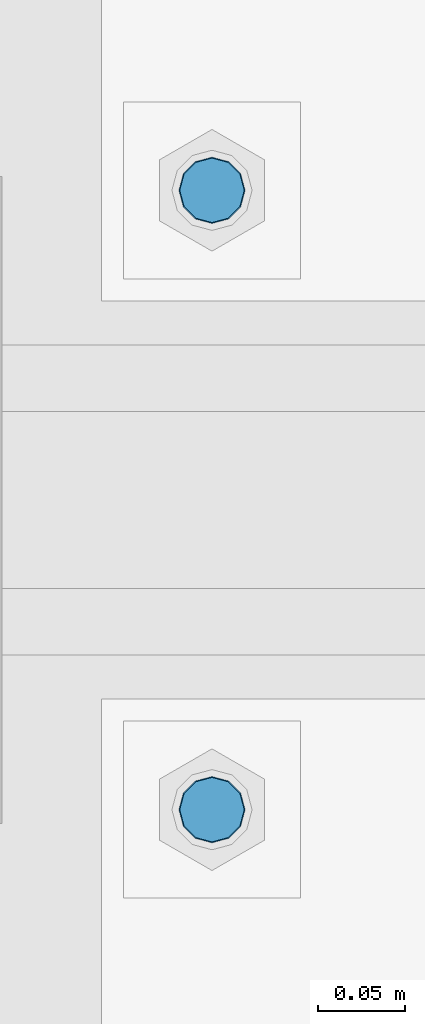
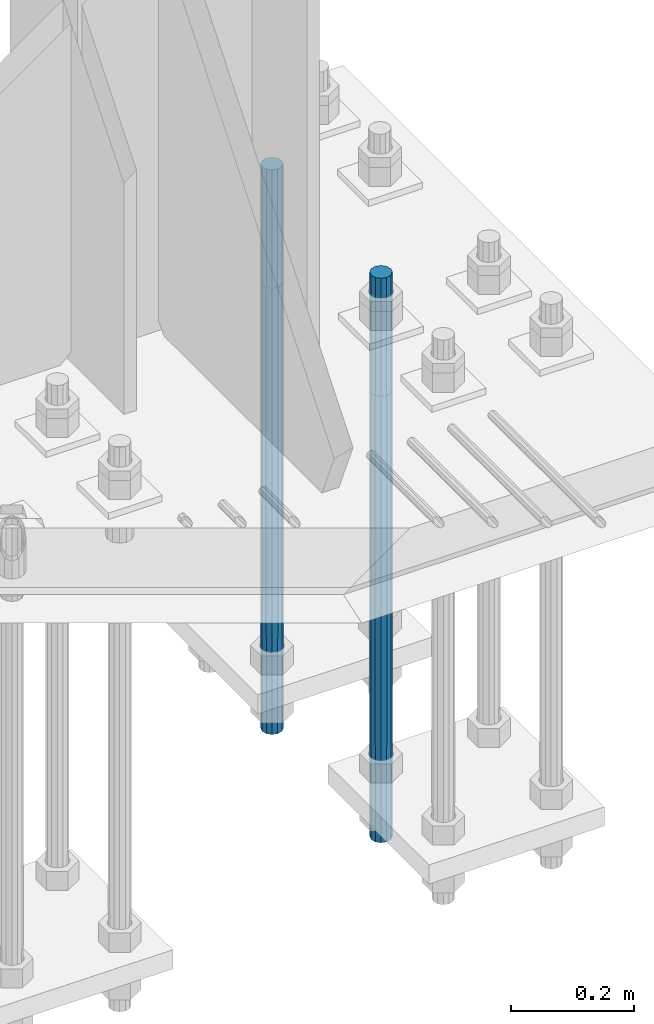
# One storey, part 1429 of 3843: 2 columns, 1 element without a shape of its own.
"""IFC2X3 building model written with IfcOpenShell, lengths in millimetres."""

import ifcopenshell
import ifcopenshell.guid

model = None  # the IFC model being written
_history = None  # IfcOwnerHistory: only IFC2X3 demands one
_inside = {}  # id of a spatial element -> (the spatial element, [elements in it])
_under = {}  # id of a project, library or spatial element -> (it, [spatial elements below it])
_declared = {}  # id of a project -> (the project, [libraries it declares])
_typed = {}  # id of a type object -> (the type object, [elements of that type])
_made_of = {}  # id of a material, layer set ... -> (it, [elements and type objects made of it])


def new_model(schema):
    """Start an empty IFC model of exactly this schema.

    Asked for "IFC4X3", IfcOpenShell would pick the latest addendum, in which some entities
    have other attributes; the version numbers below select the first issue.
    IFC2X3 requires an IfcOwnerHistory on every rooted entity: one is made here for all.
    """
    global model, _history
    if schema == "IFC4X3":
        model = ifcopenshell.file(schema_version=(4, 3, 0, 0))
    else:
        model = ifcopenshell.file(schema=schema)
    _inside.clear()
    _under.clear()
    _declared.clear()
    _typed.clear()
    _made_of.clear()
    _history = None
    if model.schema == "IFC2X3":
        org = make("IfcOrganization", Name="unknown")
        user = make(
            "IfcPersonAndOrganization",
            ThePerson=make("IfcPerson", FamilyName="unknown"),
            TheOrganization=org,
        )
        app = make(
            "IfcApplication",
            ApplicationDeveloper=org,
            Version="unknown",
            ApplicationFullName="unknown",
            ApplicationIdentifier="unknown",
        )
        _history = make(
            "IfcOwnerHistory",
            OwningUser=user,
            OwningApplication=app,
            ChangeAction="ADDED",
            CreationDate=0,
        )
    return model


def make(cls, **values):
    """One entity of the class cls with the attributes given. An attribute that is None is left unset."""
    return model.create_entity(
        cls, **{name: value for name, value in values.items() if value is not None}
    )


def rooted(cls, **values):
    """An entity with a GlobalId (a new one), such as an element, a storey or a relation."""
    return make(cls, GlobalId=ifcopenshell.guid.new(), OwnerHistory=_history, **values)


def si_unit(unit_type, name, prefix=None):
    """IfcSIUnit, for example si_unit("LENGTHUNIT", "METRE", prefix="MILLI")."""
    return make("IfcSIUnit", UnitType=unit_type, Prefix=prefix, Name=name)


def assignment(units):
    """IfcUnitAssignment: the units of a project."""
    return None if units is None else make("IfcUnitAssignment", Units=units)


def point(xyz):
    """IfcCartesianPoint."""
    return None if xyz is None else make("IfcCartesianPoint", Coordinates=xyz)


def direction(xyz):
    """IfcDirection."""
    return None if xyz is None else make("IfcDirection", DirectionRatios=xyz)


def frame(location, z_axis=None, x_axis=None):
    """IfcAxis2Placement3D, a coordinate frame: its origin and axes. An axis left out is left unset."""
    return make(
        "IfcAxis2Placement3D",
        Location=point(location),
        Axis=direction(z_axis),
        RefDirection=direction(x_axis),
    )


def origin_with_axes():
    """The frame at (0, 0, 0) with the z axis (0, 0, 1) and the x axis (1, 0, 0) written out."""
    return frame((0.0, 0.0, 0.0), z_axis=(0.0, 0.0, 1.0), x_axis=(1.0, 0.0, 0.0))


def place(relative_to, where):
    """IfcLocalPlacement: puts the frame where relative to a parent placement (None: the world)."""
    return make(
        "IfcLocalPlacement", PlacementRelTo=relative_to, RelativePlacement=where
    )


def context(
    kind, dimensions, precision=None, world=None, true_north=None, identifier=None
):
    """IfcGeometricRepresentationContext, for example the 3D "Model" context."""
    return make(
        "IfcGeometricRepresentationContext",
        ContextIdentifier=identifier,
        ContextType=kind,
        CoordinateSpaceDimension=dimensions,
        Precision=precision,
        WorldCoordinateSystem=world,
        TrueNorth=true_north,
    )


def subcontext(parent, identifier, kind, view, scale=None):
    """IfcGeometricRepresentationSubContext, for example "Body" below "Model"."""
    return make(
        "IfcGeometricRepresentationSubContext",
        ContextIdentifier=identifier,
        ContextType=kind,
        ParentContext=parent,
        TargetScale=scale,
        TargetView=view,
    )


def project(units=None, contexts=None):
    """IfcProject with its units and contexts."""
    return rooted(
        "IfcProject",
        Name="project",
        RepresentationContexts=contexts,
        UnitsInContext=assignment(units),
    )


def spatial(cls, under=None, at=None, **own):
    """A site, building, storey or space (cls), placed at a placement, below another one or the project."""
    s = rooted(cls, ObjectPlacement=at, **own)
    if under is not None:
        _under.setdefault(under.id(), (under, []))[1].append(s)
    return s


def faces_of(points, faces, orient=None, outer=None):
    """IfcFace entities. A face is a list of loops; a loop is a list of indices into points, from 0.

    orient and outer hold one flag for each loop. By default every Orientation is true, the
    first loop of a face is its IfcFaceOuterBound and the others are IfcFaceBound.
    """
    made = []
    for i, loops in enumerate(faces):
        bounds = []
        for j, loop in enumerate(loops):
            is_outer = j == 0 if outer is None else outer[i][j]
            bounds.append(
                make(
                    "IfcFaceOuterBound" if is_outer else "IfcFaceBound",
                    Bound=make("IfcPolyLoop", Polygon=[points[k] for k in loop]),
                    Orientation=True if orient is None else orient[i][j],
                )
            )
        made.append(make("IfcFace", Bounds=bounds))
    return made


def faceted_brep(points, faces, orient=None, outer=None, voids=None):
    """IfcFacetedBrep: a solid bounded by flat faces; with voids (closed shells), ...WithVoids."""
    shared = [point(p) for p in points]
    hull = make("IfcClosedShell", CfsFaces=faces_of(shared, faces, orient, outer))
    if voids is None:
        return make("IfcFacetedBrep", Outer=hull)
    return make(
        "IfcFacetedBrepWithVoids",
        Outer=hull,
        Voids=[
            make(cls, CfsFaces=faces_of(shared, fs, o, b)) for cls, fs, o, b in voids
        ],
    )


def shape(context_of_items, identifier, shape_type, items):
    """IfcShapeRepresentation: the items that make up one representation, for example the "Body"."""
    return make(
        "IfcShapeRepresentation",
        ContextOfItems=context_of_items,
        RepresentationIdentifier=identifier,
        RepresentationType=shape_type,
        Items=items,
    )


def material(Name=None, Category=None):
    """IfcMaterial."""
    return make("IfcMaterial", Name=Name, Category=Category)


def made_of(thing, what):
    """Note that an element or type object is made of a material, layer set ...; save() writes the relation."""
    if what is not None:
        _made_of.setdefault(what.id(), (what, []))[1].append(thing)
    return thing


def type_object(cls, material=None, **own):
    """A type object (cls), such as IfcWallType, which elements share."""
    return made_of(rooted(cls, **own), material)


def element(
    cls,
    number,
    at=None,
    inside=None,
    cuts=None,
    type_object=None,
    material=None,
    context=None,
    identifier="Body",
    shape_type=None,
    held_by="IfcProductDefinitionShape",
    body=None,
    shapes=None,
    **own,
):
    """One element of the class cls, such as IfcWall. Its Tag is "e" and its number.

    at: its placement. inside: the storey or other place that contains it. cuts: it is an
    opening in that element (IfcRelVoidsElement). A single representation is given by context,
    identifier, shape_type and body (its items); several are given by shapes. held_by: the class
    of the entity that holds the representations. save() writes the other relations.
    """
    e = rooted(cls, Tag="e%d" % number, ObjectPlacement=at, **own)
    if body is not None:
        shapes = [shape(context, identifier, shape_type, body)]
    if shapes is not None:
        e.Representation = make(held_by, Representations=shapes)
    if inside is not None:
        _inside.setdefault(inside.id(), (inside, []))[1].append(e)
    if cuts is not None:
        rooted(
            "IfcRelVoidsElement", RelatingBuildingElement=cuts, RelatedOpeningElement=e
        )
    if type_object is not None:
        _typed.setdefault(type_object.id(), (type_object, []))[1].append(e)
    return made_of(e, material)


def aggregate(whole, parts):
    """IfcRelAggregates: a whole, such as a stair, and the parts it consists of."""
    return rooted("IfcRelAggregates", RelatingObject=whole, RelatedObjects=parts)


def save(model, path):
    """Write the relations noted so far, then the file.

    IfcRelAggregates (storeys below a building ...), IfcRelContainedInSpatialStructure (elements
    in a storey), IfcRelDefinesByType, IfcRelAssociatesMaterial and IfcRelDeclares: one each for
    every whole, place, type object, material and project.
    """
    for whole, parts in _under.values():
        aggregate(whole, parts)
    for where, things in _inside.values():
        rooted(
            "IfcRelContainedInSpatialStructure",
            RelatedElements=things,
            RelatingStructure=where,
        )
    for kind, things in _typed.values():
        rooted("IfcRelDefinesByType", RelatedObjects=things, RelatingType=kind)
    for what, things in _made_of.values():
        rooted("IfcRelAssociatesMaterial", RelatedObjects=things, RelatingMaterial=what)
    for by, libraries in _declared.values():
        rooted("IfcRelDeclares", RelatingContext=by, RelatedDefinitions=libraries)
    model.write(path)


model = new_model("IFC2X3")

# Units and contexts
model_context = context("Model", 3, precision=1e-05, world=origin_with_axes())
body_context = subcontext(model_context, "Body", "Model", "MODEL_VIEW")
ifc_project = project(units=[si_unit("LENGTHUNIT", "METRE", prefix="MILLI"), si_unit("AREAUNIT", "SQUARE_METRE"), si_unit("VOLUMEUNIT", "CUBIC_METRE"), si_unit("MASSUNIT", "GRAM", prefix="KILO"), si_unit("TIMEUNIT", "SECOND"), si_unit("PLANEANGLEUNIT", "RADIAN"), si_unit("SOLIDANGLEUNIT", "STERADIAN"), si_unit("THERMODYNAMICTEMPERATUREUNIT", "DEGREE_CELSIUS"), si_unit("LUMINOUSINTENSITYUNIT", "LUMEN")], contexts=[model_context])

# Site, building, storey
site_placement = place(None, origin_with_axes())
site = spatial("IfcSite", under=ifc_project, at=site_placement, CompositionType="ELEMENT")
building_placement = place(site_placement, origin_with_axes())
building = spatial("IfcBuilding", under=site, at=building_placement, Name="Undefined", CompositionType="ELEMENT")
storey_placement = place(building_placement, origin_with_axes())
storey = spatial("IfcBuildingStorey", under=building, at=storey_placement, Name="Undefined", CompositionType="ELEMENT", Elevation=0.0)

# Assembly, columns
assembly_placement = place(storey_placement, origin_with_axes())
assembly = element("IfcElementAssembly", 1, at=assembly_placement, inside=storey, Name="TEMPLATE", AssemblyPlace="NOTDEFINED", PredefinedType="RIGID_FRAME")
ifc_material = material(Name="Undefined/F1554-GR.55")
column_type = type_object("IfcColumnType", PredefinedType="NOTDEFINED")
column_1_placement = place(assembly_placement, frame((85953.6, 104381.3, 29565.6), z_axis=(1.0, 0.0, 0.0), x_axis=(0.0, 0.0, -1.0)))
column_1 = element("IfcColumn", 2, at=column_1_placement, type_object=column_type, material=ifc_material, Name="ANCHOR_ROD", context=body_context, shape_type="Brep", body=[
    faceted_brep([(-234.950000000001, -16.0214699700155, 9.25), (-234.950000000001, -9.25, 16.0214699700155), (-234.950000000001, 0.0, 18.5), (-234.950000000001, 9.25, 16.0214699700155), (-234.950000000001, 16.0214699700155, 9.25), (-234.950000000001, 18.5, 0.0), (-234.950000000001, 16.0214699700155, -9.25), (-234.950000000001, 9.25, -16.0214699700155), (-234.950000000001, 0.0, -18.5), (-234.950000000001, -9.25, -16.0214699700155), (-234.950000000001, -16.0214699700155, -9.25), (-234.950000000001, -18.5, 0.0), (0.0, 18.5, 0.0), (0.0, 16.0214699700118, -9.25), (0.0, 9.25, -16.0214699700155), (0.0, 0.0, -18.5), (0.0, -9.25, -16.0214699700155), (0.0, -16.0214699700118, -9.25), (0.0, -18.5, 0.0), (0.0, -16.0214699700118, 9.25), (0.0, -9.25, 16.0214699700155), (0.0, 0.0, 18.5), (0.0, 9.25, 16.0214699700155), (0.0, 16.0214699700118, 9.25), (0.0, -16.4977839420972, 9.52500000000146), (0.0, -9.52500000000146, 16.4977839420972), (0.0, 0.0, 19.0499989999989), (0.0, 9.52500000000146, 16.4977839420972), (0.0, 16.4977839420972, 9.52500000000146), (0.0, 19.0500000000029, 0.0), (0.0, 16.4977839420972, -9.52500000000146), (0.0, 9.52500000000146, -16.4977839420972), (0.0, 0.0, -19.0499989999989), (0.0, -9.52500000000146, -16.4977839420972), (0.0, -16.4977839420972, -9.52500000000146), (0.0, -19.0500000000029, 0.0), (698.5, -19.0499999999993, 0.0), (698.5, -16.4977839420935, 9.52499999999418), (698.5, -9.52500000000146, 16.4977839420899), (698.5, 0.0, 19.0500000000029), (698.5, 9.52500000000146, 16.4977839420899), (698.5, 16.4977839420935, 9.52499999999418), (698.5, 19.0499999999993, 0.0), (698.5, 16.4977839420935, -9.52499999999418), (698.5, 9.52500000000146, -16.4977839420899), (698.5, 0.0, -19.0500000000029), (698.5, -9.52500000000146, -16.4977839420899), (698.5, -16.4977839420935, -9.52499999999418), (698.5, -9.25, 16.0214699700155), (698.5, 0.0, 18.5), (698.5, 9.25, 16.0214699700155), (698.5, 16.0214699700118, 9.25), (698.5, 18.5, 0.0), (698.5, 16.0214699700118, -9.25), (698.5, 9.25, -16.0214699700155), (698.5, 0.0, -18.5), (698.5, -9.25, -16.0214699700155), (698.5, -16.0214699700118, -9.25), (698.5, -18.5, 0.0), (698.5, -16.0214699700118, 9.25), (889.0, -9.25, -16.0214699700155), (889.0, 0.0, -18.5), (889.0, 9.25, -16.0214699700155), (889.0, 16.0214699700118, -9.25), (889.0, 18.5, 0.0), (889.0, 16.0214699700118, 9.25), (889.0, 9.25, 16.0214699700155), (889.0, 0.0, 18.5), (889.0, -9.25, 16.0214699700155), (889.0, -16.0214699700118, 9.25), (889.0, -18.5, 0.0), (889.0, -16.0214699700118, -9.25)], [[[0, 1, 2, 3, 4, 5, 6, 7, 8, 9, 10, 11]], [[6, 5, 12, 13]], [[7, 6, 13, 14]], [[8, 7, 14, 15]], [[9, 8, 15, 16]], [[10, 9, 16, 17]], [[11, 10, 17, 18]], [[0, 11, 18, 19]], [[1, 0, 19, 20]], [[2, 1, 20, 21]], [[3, 2, 21, 22]], [[4, 3, 22, 23]], [[5, 4, 23, 12]], [[24, 25, 26, 27, 28, 29, 30, 31, 32, 33, 34, 35], [22, 21, 20, 19, 18, 17, 16, 15, 14, 13, 12, 23]], [[24, 35, 36, 37]], [[25, 24, 37, 38]], [[26, 25, 38, 39]], [[27, 26, 39, 40]], [[28, 27, 40, 41]], [[29, 28, 41, 42]], [[30, 29, 42, 43]], [[31, 30, 43, 44]], [[32, 31, 44, 45]], [[33, 32, 45, 46]], [[34, 33, 46, 47]], [[35, 34, 47, 36]], [[46, 45, 44, 43, 42, 41, 40, 39, 38, 37, 36, 47], [48, 49, 50, 51, 52, 53, 54, 55, 56, 57, 58, 59]], [[60, 61, 62, 63, 64, 65, 66, 67, 68, 69, 70, 71]], [[68, 67, 49, 48]], [[69, 68, 48, 59]], [[70, 69, 59, 58]], [[71, 70, 58, 57]], [[60, 71, 57, 56]], [[61, 60, 56, 55]], [[62, 61, 55, 54]], [[63, 62, 54, 53]], [[64, 63, 53, 52]], [[65, 64, 52, 51]], [[66, 65, 51, 50]], [[67, 66, 50, 49]]]),
])
column_2_placement = place(assembly_placement, frame((85953.6, 104736.9, 29565.6), z_axis=(-1.0, 0.0, 0.0), x_axis=(0.0, 0.0, -1.0)))
column_2 = element("IfcColumn", 3, at=column_2_placement, type_object=column_type, material=ifc_material, Name="ANCHOR_ROD", context=body_context, shape_type="Brep", body=[
    faceted_brep([(-234.950000000001, -16.0214699700155, 9.25), (-234.950000000001, -9.25, 16.0214699700155), (-234.950000000001, 0.0, 18.5), (-234.950000000001, 9.25, 16.0214699700155), (-234.950000000001, 16.0214699700155, 9.25), (-234.950000000001, 18.5, 0.0), (-234.950000000001, 16.0214699700155, -9.25), (-234.950000000001, 9.25, -16.0214699700155), (-234.950000000001, 0.0, -18.5), (-234.950000000001, -9.25, -16.0214699700155), (-234.950000000001, -16.0214699700155, -9.25), (-234.950000000001, -18.5, 0.0), (0.0, 18.5, 0.0), (0.0, 16.0214699700118, -9.25), (0.0, 9.25, -16.0214699700155), (0.0, 0.0, -18.5), (0.0, -9.25, -16.0214699700155), (0.0, -16.0214699700118, -9.25), (0.0, -18.5, 0.0), (0.0, -16.0214699700118, 9.25), (0.0, -9.25, 16.0214699700155), (0.0, 0.0, 18.5), (0.0, 9.25, 16.0214699700155), (0.0, 16.0214699700118, 9.25), (0.0, -16.4977839420972, 9.52500000000146), (0.0, -9.52500000000146, 16.4977839420972), (0.0, 0.0, 19.0499989999989), (0.0, 9.52500000000146, 16.4977839420972), (0.0, 16.4977839420972, 9.52500000000146), (0.0, 19.0500000000029, 0.0), (0.0, 16.4977839420972, -9.52500000000146), (0.0, 9.52500000000146, -16.4977839420972), (0.0, 0.0, -19.0499989999989), (0.0, -9.52500000000146, -16.4977839420972), (0.0, -16.4977839420972, -9.52500000000146), (0.0, -19.0500000000029, 0.0), (698.5, -19.0499999999993, 0.0), (698.5, -16.4977839420935, 9.52499999999418), (698.5, -9.52500000000146, 16.4977839420899), (698.5, 0.0, 19.0500000000029), (698.5, 9.52500000000146, 16.4977839420899), (698.5, 16.4977839420935, 9.52499999999418), (698.5, 19.0499999999993, 0.0), (698.5, 16.4977839420935, -9.52499999999418), (698.5, 9.52500000000146, -16.4977839420899), (698.5, 0.0, -19.0500000000029), (698.5, -9.52500000000146, -16.4977839420899), (698.5, -16.4977839420935, -9.52499999999418), (698.5, -9.25, 16.0214699700155), (698.5, 0.0, 18.5), (698.5, 9.25, 16.0214699700155), (698.5, 16.0214699700118, 9.25), (698.5, 18.5, 0.0), (698.5, 16.0214699700118, -9.25), (698.5, 9.25, -16.0214699700155), (698.5, 0.0, -18.5), (698.5, -9.25, -16.0214699700155), (698.5, -16.0214699700118, -9.25), (698.5, -18.5, 0.0), (698.5, -16.0214699700118, 9.25), (889.0, -9.25, -16.0214699700155), (889.0, 0.0, -18.5), (889.0, 9.25, -16.0214699700155), (889.0, 16.0214699700118, -9.25), (889.0, 18.5, 0.0), (889.0, 16.0214699700118, 9.25), (889.0, 9.25, 16.0214699700155), (889.0, 0.0, 18.5), (889.0, -9.25, 16.0214699700155), (889.0, -16.0214699700118, 9.25), (889.0, -18.5, 0.0), (889.0, -16.0214699700118, -9.25)], [[[0, 1, 2, 3, 4, 5, 6, 7, 8, 9, 10, 11]], [[6, 5, 12, 13]], [[7, 6, 13, 14]], [[8, 7, 14, 15]], [[9, 8, 15, 16]], [[10, 9, 16, 17]], [[11, 10, 17, 18]], [[0, 11, 18, 19]], [[1, 0, 19, 20]], [[2, 1, 20, 21]], [[3, 2, 21, 22]], [[4, 3, 22, 23]], [[5, 4, 23, 12]], [[24, 25, 26, 27, 28, 29, 30, 31, 32, 33, 34, 35], [22, 21, 20, 19, 18, 17, 16, 15, 14, 13, 12, 23]], [[24, 35, 36, 37]], [[25, 24, 37, 38]], [[26, 25, 38, 39]], [[27, 26, 39, 40]], [[28, 27, 40, 41]], [[29, 28, 41, 42]], [[30, 29, 42, 43]], [[31, 30, 43, 44]], [[32, 31, 44, 45]], [[33, 32, 45, 46]], [[34, 33, 46, 47]], [[35, 34, 47, 36]], [[46, 45, 44, 43, 42, 41, 40, 39, 38, 37, 36, 47], [48, 49, 50, 51, 52, 53, 54, 55, 56, 57, 58, 59]], [[60, 61, 62, 63, 64, 65, 66, 67, 68, 69, 70, 71]], [[68, 67, 49, 48]], [[69, 68, 48, 59]], [[70, 69, 59, 58]], [[71, 70, 58, 57]], [[60, 71, 57, 56]], [[61, 60, 56, 55]], [[62, 61, 55, 54]], [[63, 62, 54, 53]], [[64, 63, 53, 52]], [[65, 64, 52, 51]], [[66, 65, 51, 50]], [[67, 66, 50, 49]]]),
])
aggregate(assembly, [column_1, column_2])

save(model, "model.ifc")
